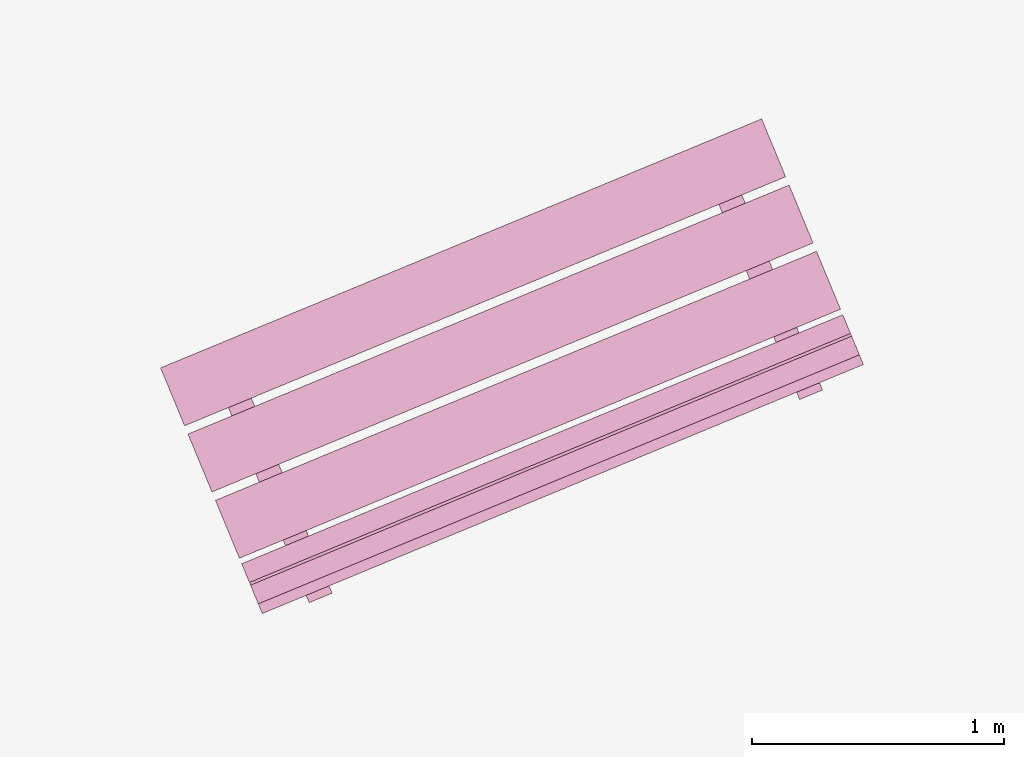
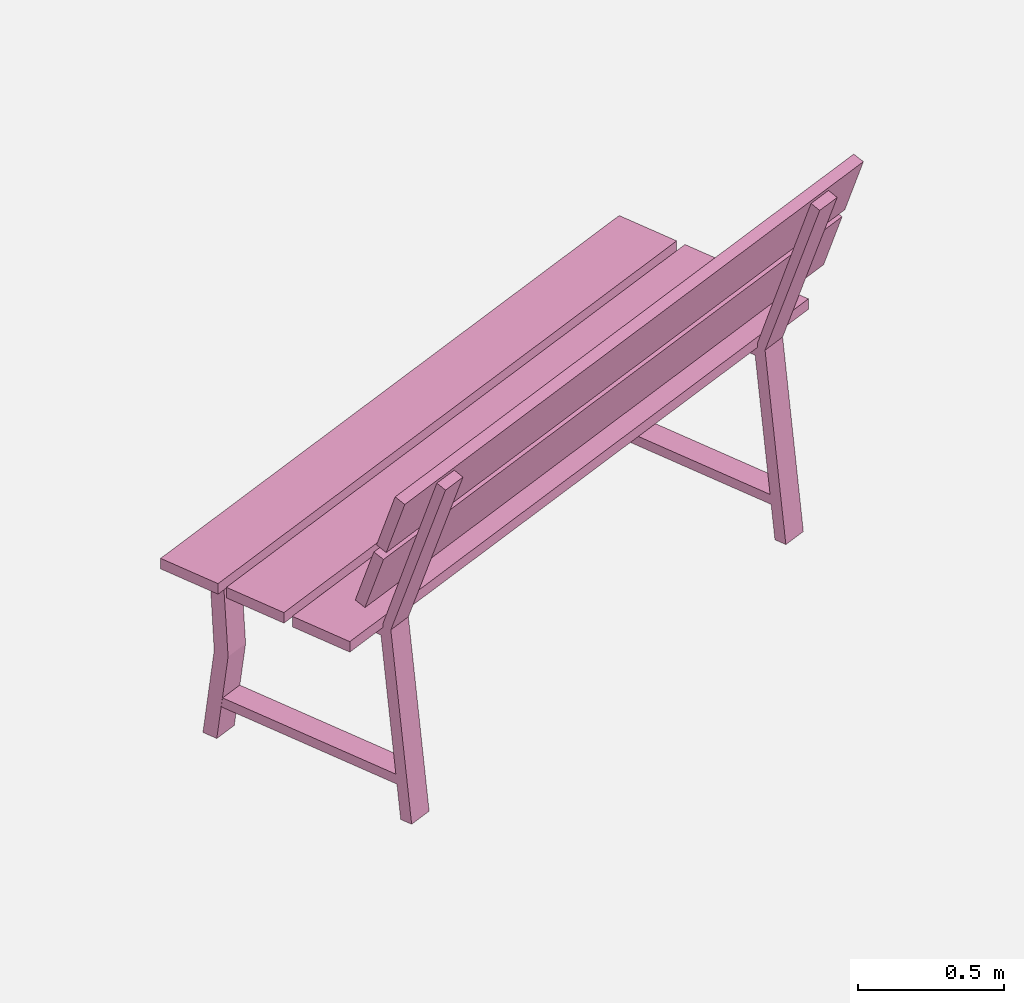
# One storey, part 11 of 200: 1 furnishing.
"""IFC4 building model written with IfcOpenShell, lengths in metres."""

from ifc_helpers import new_model, si_unit, origin_with_axes, place, context, subcontext, project, spatial, triangles, material, element, save


model = new_model("IFC4")

# Units and contexts
model_context = context("Model", 3, precision=1e-05, world=origin_with_axes())
body_context = subcontext(model_context, "Body", "Model", "MODEL_VIEW")
ifc_project = project(units=[si_unit("VOLUMEUNIT", "CUBIC_METRE"), si_unit("LENGTHUNIT", "METRE"), si_unit("AREAUNIT", "SQUARE_METRE")], contexts=[model_context])

# Site, building, storey
site_placement = place(None, origin_with_axes())
site = spatial("IfcSite", under=ifc_project, at=site_placement)
building_placement = place(site_placement, origin_with_axes())
building = spatial("IfcBuilding", under=site, at=building_placement, Name="Building")
storey_placement = place(building_placement, origin_with_axes())
storey = spatial("IfcBuildingStorey", under=building, at=storey_placement, Name="Ground")

# Furnishing
ifc_material = material(Name="bench")
furnishing_placement = place(storey_placement, origin_with_axes())
element("IfcFurnishingElement", 1, at=furnishing_placement, inside=storey, material=ifc_material, Name="cw_instances_bench_36", context=body_context, shape_type="Tessellation", body=[
    triangles([(256.50131582265743, -643.1444984934304, 0.815520754558246), (256.5963253395347, -643.3738717576301, 0.815520754558246), (258.9794318354867, -642.3867567264274, 0.815520754558246), (258.88442231860944, -642.1573834622277, 0.815520754558246), (258.6579446196618, -642.1031759975924, 0.36316797911391596), (258.56708614920547, -642.1408108083118, 0.36316797911391596), (258.5483917027562, -642.095678422153, 1.4462435886752271e-07), (258.63925017321253, -642.0580436114335, 1.4462435886752271e-07), (258.54414857800714, -642.0854346128369, 0.36316797911391596), (258.6163740845442, -642.0028158479163, 1.6069373207502523e-07), (258.52551561408785, -642.0404506586358, 1.6069373207502523e-07), (258.6350070484634, -642.0477998021174, 0.36316797911391596), (258.8358185824645, -642.7895882933353, 0.7742224172068448), (258.8358185824645, -642.7895882933353, 0.7742224172068448), (258.8701941426517, -642.8725782369535, 0.0), (258.96105261310805, -642.834943426234, 0.0), (258.96105261310805, -642.834943426234, 0.0), (258.92712242302485, -642.7517690042785, 0.7742224172068448), (258.81952244664325, -642.7502459412215, 0.7346917591163886), (258.9430346159267, -642.791444133072, 1.6069373207502518e-08), (258.85217614547037, -642.8290789437915, 1.6069373207502518e-08), (258.9103809170996, -642.712611130502, 0.7353345501140619), (258.64872041376776, -642.0809067946209, 0.7353346465303011), (258.55773895365354, -642.1182446820402, 0.7346918555326278), (258.5346169102673, -642.0624231313074, 0.7742225618312036), (258.6259207508276, -642.0246038422505, 0.7742225618312036), (256.39265446605225, -642.8821667726082, 0.8155208509744852), (256.48766397678, -643.1115400219618, 0.815520754558246), (258.870770472732, -642.124424990759, 0.815520754558246), (258.7757609620042, -641.8950517414056, 0.8155208509744852), (256.6101616760485, -643.4072756288951, 0.815520754558246), (256.7051711867763, -643.6366488782486, 0.8155206581420068), (259.08827768272823, -642.6495338470459, 0.8155206581420068), (258.99326817200046, -642.4201605976924, 0.815520754558246), (256.71427242761035, -643.6586212173047, 0.9999971268416286), (259.1280648678063, -642.7455886088701, 1.2349312667190762), (259.0973789235623, -642.671506186102, 0.9999971268416286), (256.74495837185435, -643.7327036400727, 1.2349312667190762), (256.7493860056882, -643.7433928937238, 1.2691590637898031), (259.16317843358524, -642.8303602555968, 1.5040931072510113), (259.13249250164023, -642.7562778625211, 1.2691590637898031), (256.7800719376333, -643.8174752867995, 1.5040931072510113), (259.0170999839093, -642.969833752017, 1.4584561837579435), (258.926241424376, -643.0074685996335, 1.4584561837579435), (258.8358185824645, -642.7895882933353, 0.7742224172068448), (258.92712242302485, -642.7517690042785, 0.7742224172068448), (258.9119797888018, -642.7164711482499, 0.7739010297426947), (258.8213057966828, -642.7545513290734, 0.7739010297426947), (258.9116671499148, -642.9722831885676, 1.4724364581016047), (259.00234123111073, -642.9342029708472, 1.4724364581016047), (259.1133060904099, -642.7099577683155, 0.9858560302109066), (259.1439305459744, -642.7838917442797, 1.2207902665045935), (256.7301995944579, -643.6970727995182, 0.9858560302109066), (256.76082405002245, -643.7710067754824, 1.2207902665045935), (259.14841966233826, -642.7947294298883, 1.2550180635753205), (259.17910560043276, -642.8688118378103, 1.4899522998690073), (256.7653131663863, -643.781844461091, 1.2550180635753205), (256.7959991044808, -643.855926869013, 1.4899522998690073), (256.7135423738886, -642.9085737785003, 0.36316797911391596), (256.62268390343223, -642.9462085892199, 0.36316797911391596), (256.60398945698296, -642.901076203061, 1.4462435886752271e-07), (256.6948479274393, -642.8634413923415, 1.4462435886752271e-07), (256.59974633223385, -642.8908323937449, 0.36316797911391596), (256.6719718387709, -642.8082136288243, 1.6069373207502523e-07), (256.5811133683146, -642.8458484395437, 1.6069373207502523e-07), (256.6906048026902, -642.8531975830253, 0.36316797911391596), (256.89141633669124, -643.5949860742434, 0.7742224172068448), (256.89141633669124, -643.5949860742434, 0.7742224172068448), (256.9257918968785, -643.6779760178614, 0.0), (257.01665036733476, -643.640341207142, 0.0), (257.01665036733476, -643.640341207142, 0.0), (256.9825717749862, -643.5572282554175, 0.7742224172068448), (256.87512020087, -643.5556437221294, 0.7346917591163886), (256.9986323701535, -643.59684191398, 1.6069373207502518e-08), (256.90777389969713, -643.6344767246995, 1.6069373207502518e-08), (256.96597867132635, -643.5180089114099, 0.7353345501140619), (256.7043181679945, -642.8863045755288, 0.7353346465303011), (256.61333670788025, -642.9236424629481, 0.7346918555326278), (256.590214664494, -642.8678209122153, 0.7742225618312036), (256.681370102789, -642.8300630933895, 0.7742225618312036), (257.07254924679364, -643.7752930400529, 1.4584561837579435), (256.98183916375655, -643.8128663866909, 1.4584561837579435), (256.89141633669124, -643.5949860742434, 0.7742224172068448), (256.9825717749862, -643.5572282554175, 0.7742224172068448), (256.96757754302854, -643.5218689291578, 0.7739010297426947), (256.87690355090956, -643.5599491099814, 0.7739010297426947), (256.9672648892954, -643.777680975625, 1.4724364581016047), (257.0577904939951, -643.7396622588831, 1.4724364581016047), (256.5963253395347, -643.3738717576301, 0.815520754558246), (258.9794318354867, -642.3867567264274, 0.7716513657017641), (258.9794318354867, -642.3867567264274, 0.815520754558246), (256.5963253395347, -643.3738717576301, 0.7716513657017641), (256.50131582265743, -643.1444984934304, 0.7716514139098837), (258.88442231860944, -642.1573834622277, 0.815520754558246), (258.88442231860944, -642.1573834622277, 0.7716514139098837), (256.50131582265743, -643.1444984934304, 0.815520754558246), (258.63925017321253, -642.0580436114335, 1.4462435886752271e-07), (258.6350070484634, -642.0477998021174, 0.36316797911391596), (258.6579446196618, -642.1031759975924, 0.36316797911391596), (258.6163740845442, -642.0028158479163, 1.6069373207502523e-07), (258.9103809170996, -642.712611130502, 0.7353345501140619), (258.92712242302485, -642.7517690042785, 0.7742224172068448), (258.96105261310805, -642.834943426234, 0.0), (258.9430346159267, -642.791444133072, 1.6069373207502518e-08), (258.54414857800714, -642.0854346128369, 0.36316797911391596), (258.56708614920547, -642.1408108083118, 0.36316797911391596), (258.55773895365354, -642.1182446820402, 0.7346918555326278), (258.5346169102673, -642.0624231313074, 0.7742225618312036), (258.8358185824645, -642.7895882933353, 0.7742224172068448), (258.81952244664325, -642.7502459412215, 0.7346917591163886), (258.8701941426517, -642.8725782369535, 0.0), (258.85217614547037, -642.8290789437915, 1.6069373207502518e-08), (258.64872041376776, -642.0809067946209, 0.7353346465303011), (258.6259207508276, -642.0246038422505, 0.7742225618312036), (258.5483917027562, -642.095678422153, 1.4462435886752271e-07), (258.52551561408785, -642.0404506586358, 1.6069373207502523e-07), (259.0170999839093, -642.969833752017, 1.4584561837579435), (258.9116671499148, -642.9722831885676, 1.4724364581016047), (258.926241424376, -643.0074685996335, 1.4584561837579435), (259.00234123111073, -642.9342029708472, 1.4724364581016047), (258.8489107512933, -642.8182561941765, 0.13996424063734697), (258.8489107512933, -642.8182561941765, 0.17949489872780322), (258.5526286715616, -642.102967979, 0.13996438526170585), (258.55244418092525, -642.1025225792037, 0.17949504335216207), (258.9379877413335, -642.7813592968065, 0.17949489872780322), (258.93769077349486, -642.7814823049129, 0.1406070155656471), (258.64153167727153, -642.0664909981903, 0.14060716019000596), (258.6415211709654, -642.0656256818336, 0.17949504335216207), (256.48766397678, -643.1115400219618, 0.815520754558246), (258.870770472732, -642.124424990759, 0.7716514139098837), (258.870770472732, -642.124424990759, 0.815520754558246), (256.48766397678, -643.1115400219618, 0.7716514139098837), (256.39265446605225, -642.8821667726082, 0.7716514621180032), (258.7757609620042, -641.8950517414056, 0.8155208509744852), (258.7757609620042, -641.8950517414056, 0.7716514621180032), (256.39265446605225, -642.8821667726082, 0.8155208509744852), (256.7051711867763, -643.6366488782486, 0.8155206581420068), (259.08827768272823, -642.6495338470459, 0.7716513174936444), (259.08827768272823, -642.6495338470459, 0.8155206581420068), (256.7051711867763, -643.6366488782486, 0.7716513174936444), (256.610161669899, -643.407275614049, 0.7716513657017641), (258.99326817200046, -642.4201605976924, 0.815520754558246), (258.99326816585096, -642.4201605828463, 0.7716513657017641), (256.6101616760485, -643.4072756288951, 0.815520754558246), (259.1439305459744, -642.7838917442797, 1.2207902665045935), (256.74495837185435, -643.7327036400727, 1.2349312667190762), (256.76082405002245, -643.7710067754824, 1.2207902665045935), (259.1280648678063, -642.7455886088701, 1.2349312667190762), (256.7301995944579, -643.6970727995182, 0.9858560302109066), (259.0973789235623, -642.671506186102, 0.9999971268416286), (259.1133060904099, -642.7099577683155, 0.9858560302109066), (256.71427242761035, -643.6586212173047, 0.9999971268416286), (259.17910560043276, -642.8688118378103, 1.4899522998690073), (256.7800719376333, -643.8174752867995, 1.5040931072510113), (256.7959991044808, -643.855926869013, 1.4899522998690073), (259.16317843358524, -642.8303602555968, 1.5040931072510113), (256.7653131663863, -643.781844461091, 1.2550180635753205), (259.13249250164023, -642.7562778625211, 1.2691590637898031), (259.14841966233826, -642.7947294298883, 1.2550180635753205), (256.7493860056882, -643.7433928937238, 1.2691590637898031), (256.6948479274393, -642.8634413923415, 1.4462435886752271e-07), (256.6906048026902, -642.8531975830253, 0.36316797911391596), (256.7135423738886, -642.9085737785003, 0.36316797911391596), (256.6719718387709, -642.8082136288243, 1.6069373207502523e-07), (256.96597867132635, -643.5180089114099, 0.7353345501140619), (256.9825717749862, -643.5572282554175, 0.7742224172068448), (257.01665036733476, -643.640341207142, 0.0), (256.9986323701535, -643.59684191398, 1.6069373207502518e-08), (256.59974633223385, -642.8908323937449, 0.36316797911391596), (256.62268390343223, -642.9462085892199, 0.36316797911391596), (256.61333670788025, -642.9236424629481, 0.7346918555326278), (256.590214664494, -642.8678209122153, 0.7742225618312036), (256.89141633669124, -643.5949860742434, 0.7742224172068448), (256.87512020087, -643.5556437221294, 0.7346917591163886), (256.9257918968785, -643.6779760178614, 0.0), (256.90777389969713, -643.6344767246995, 1.6069373207502518e-08), (256.7043181679945, -642.8863045755288, 0.7353346465303011), (256.681370102789, -642.8300630933895, 0.7742225618312036), (256.60398945698296, -642.901076203061, 1.4462435886752271e-07), (256.5811133683146, -642.8458484395437, 1.6069373207502523e-07), (257.07254924679364, -643.7752930400529, 1.4584561837579435), (256.9672648892954, -643.777680975625, 1.4724364581016047), (256.98183916375655, -643.8128663866909, 1.4584561837579435), (257.0577904939951, -643.7396622588831, 1.4724364581016047), (256.90436001417766, -643.6237154822124, 0.13996424063734697), (256.90436001417766, -643.6237154822124, 0.17949489872780322), (256.60807793444593, -642.9084272670359, 0.13996438526170585), (256.6078934438096, -642.9079818672395, 0.17949504335216207), (256.99358549556024, -643.5867570777144, 0.17949489872780322), (256.9931401254562, -643.5869415560518, 0.1406070155656471), (256.69698102923286, -642.8719502493293, 0.14060716019000596), (256.69711892519217, -642.8710234627416, 0.17949504335216207), (256.50131582265743, -643.1444984934304, 0.815520754558246), (256.5963253395347, -643.3738717576301, 0.7716513657017641), (256.5963253395347, -643.3738717576301, 0.815520754558246), (256.50131582265743, -643.1444984934304, 0.7716514139098837), (258.9794318354867, -642.3867567264274, 0.815520754558246), (258.9794318354867, -642.3867567264274, 0.7716513657017641), (258.88442231860944, -642.1573834622277, 0.7716514139098837), (258.88442231860944, -642.1573834622277, 0.815520754558246), (256.39265446605225, -642.8821667726082, 0.8155208509744852), (256.48766397678, -643.1115400219618, 0.7716514139098837), (256.48766397678, -643.1115400219618, 0.815520754558246), (256.39265446605225, -642.8821667726082, 0.7716514621180032), (258.870770472732, -642.124424990759, 0.815520754558246), (258.870770472732, -642.124424990759, 0.7716514139098837), (258.7757609620042, -641.8950517414056, 0.7716514621180032), (258.7757609620042, -641.8950517414056, 0.8155208509744852), (256.6101616760485, -643.4072756288951, 0.815520754558246), (256.7051711867763, -643.6366488782486, 0.7716513174936444), (256.7051711867763, -643.6366488782486, 0.8155206581420068), (256.610161669899, -643.407275614049, 0.7716513657017641), (259.08827768272823, -642.6495338470459, 0.8155206581420068), (259.08827768272823, -642.6495338470459, 0.7716513174936444), (258.99326816585096, -642.4201605828463, 0.7716513657017641), (258.99326817200046, -642.4201605976924, 0.815520754558246), (256.7301995944579, -643.6970727995182, 0.9858560302109066), (256.76082405002245, -643.7710067754824, 1.2207902665045935), (256.74495837185435, -643.7327036400727, 1.2349312667190762), (256.71427242761035, -643.6586212173047, 0.9999971268416286), (259.1280648678063, -642.7455886088701, 1.2349312667190762), (259.1133060904099, -642.7099577683155, 0.9858560302109066), (259.0973789235623, -642.671506186102, 0.9999971268416286), (259.1439305459744, -642.7838917442797, 1.2207902665045935), (256.7653131663863, -643.781844461091, 1.2550180635753205), (256.7959991044808, -643.855926869013, 1.4899522998690073), (256.7800719376333, -643.8174752867995, 1.5040931072510113), (256.7493860056882, -643.7433928937238, 1.2691590637898031), (259.16317843358524, -642.8303602555968, 1.5040931072510113), (259.14841966233826, -642.7947294298883, 1.2550180635753205), (259.13249250164023, -642.7562778625211, 1.2691590637898031), (259.17910560043276, -642.8688118378103, 1.4899522998690073), (258.8213057966828, -642.7545513290734, 0.7739010297426947), (258.9116671499148, -642.9722831885676, 1.4724364581016047), (258.926241424376, -643.0074685996335, 1.4584561837579435), (258.92712242302485, -642.7517690042785, 0.7742224172068448), (258.9119797888018, -642.7164711482499, 0.7739010297426947), (259.00234123111073, -642.9342029708472, 1.4724364581016047), (259.0170999839093, -642.969833752017, 1.4584561837579435), (256.87690355090956, -643.5599491099814, 0.7739010297426947), (256.9672648892954, -643.777680975625, 1.4724364581016047), (256.98183916375655, -643.8128663866909, 1.4584561837579435), (256.9825717749862, -643.5572282554175, 0.7742224172068448), (256.96757754302854, -643.5218689291578, 0.7739010297426947), (257.0577904939951, -643.7396622588831, 1.4724364581016047), (257.07254924679364, -643.7752930400529, 1.4584561837579435), (258.8358185824645, -642.7895882933353, 0.7742224172068448), (258.92712242302485, -642.7517690042785, 0.7742224172068448), (258.5346169102673, -642.0624231313074, 0.7742225618312036), (258.6259207508276, -642.0246038422505, 0.7742225618312036), (258.8489107512933, -642.8182561941765, 0.17949489872780322), (258.9379877413335, -642.7813592968065, 0.17949489872780322), (258.55244418092525, -642.1025225792037, 0.17949504335216207), (258.6415211709654, -642.0656256818336, 0.17949504335216207), (256.89141633669124, -643.5949860742434, 0.7742224172068448), (256.9825717749862, -643.5572282554175, 0.7742224172068448), (256.590214664494, -642.8678209122153, 0.7742225618312036), (256.681370102789, -642.8300630933895, 0.7742225618312036), (256.90436001417766, -643.6237154822124, 0.17949489872780322), (256.99358549556024, -643.5867570777144, 0.17949489872780322), (256.6078934438096, -642.9079818672395, 0.17949504335216207), (256.69711892519217, -642.8710234627416, 0.17949504335216207)], [[1, 2, 3], [3, 4, 1], [5, 6, 7], [7, 8, 5], [9, 10, 11], [10, 9, 12], [14, 15, 16], [17, 18, 13], [19, 20, 21], [20, 19, 22], [23, 24, 5], [24, 6, 5], [12, 9, 25], [25, 26, 12], [27, 28, 29], [29, 30, 27], [31, 32, 33], [33, 34, 31], [35, 36, 37], [35, 38, 36], [39, 40, 41], [39, 42, 40], [43, 44, 45], [45, 46, 43], [47, 48, 49], [49, 50, 47], [51, 52, 53], [54, 53, 52], [55, 56, 57], [58, 57, 56], [59, 60, 61], [61, 62, 59], [63, 64, 65], [64, 63, 66], [68, 69, 71], [70, 72, 67], [73, 74, 75], [74, 73, 76], [77, 78, 59], [78, 60, 59], [66, 63, 79], [79, 80, 66], [81, 82, 83], [83, 84, 81], [85, 86, 87], [87, 88, 85], [89, 90, 91], [89, 92, 90], [93, 94, 95], [93, 96, 94], [97, 98, 99], [97, 100, 98], [101, 102, 103], [103, 104, 101], [105, 106, 107], [107, 108, 105], [109, 110, 111], [110, 112, 111], [108, 107, 109], [107, 110, 109], [113, 99, 98], [98, 114, 113], [115, 106, 105], [105, 116, 115], [117, 118, 119], [117, 120, 118], [102, 101, 113], [113, 114, 102], [121, 122, 123], [122, 124, 123], [125, 126, 127], [127, 128, 125], [129, 130, 131], [129, 132, 130], [133, 134, 135], [133, 136, 134], [137, 138, 139], [137, 140, 138], [141, 142, 143], [141, 144, 142], [145, 146, 147], [145, 148, 146], [149, 150, 151], [149, 152, 150], [153, 154, 155], [153, 156, 154], [157, 158, 159], [157, 160, 158], [161, 162, 163], [161, 164, 162], [165, 166, 167], [167, 168, 165], [169, 170, 171], [171, 172, 169], [173, 174, 175], [174, 176, 175], [172, 171, 173], [171, 174, 173], [177, 163, 162], [162, 178, 177], [179, 170, 169], [169, 180, 179], [181, 182, 183], [181, 184, 182], [166, 165, 177], [177, 178, 166], [185, 186, 187], [186, 188, 187], [189, 190, 191], [191, 192, 189], [193, 194, 195], [194, 193, 196], [197, 198, 199], [199, 200, 197], [201, 202, 203], [202, 201, 204], [205, 206, 207], [207, 208, 205], [209, 210, 211], [210, 209, 212], [213, 214, 215], [215, 216, 213], [217, 218, 219], [219, 220, 217], [221, 222, 223], [222, 221, 224], [225, 226, 227], [227, 228, 225], [229, 230, 231], [230, 229, 232], [233, 109, 234], [109, 235, 234], [236, 237, 238], [238, 239, 236], [240, 173, 241], [173, 242, 241], [243, 244, 245], [245, 246, 243], [247, 248, 249], [248, 250, 249], [251, 252, 253], [252, 254, 253], [255, 256, 257], [256, 258, 257], [259, 260, 261], [260, 262, 261]], closed=True),
])

save(model, "model.ifc")
